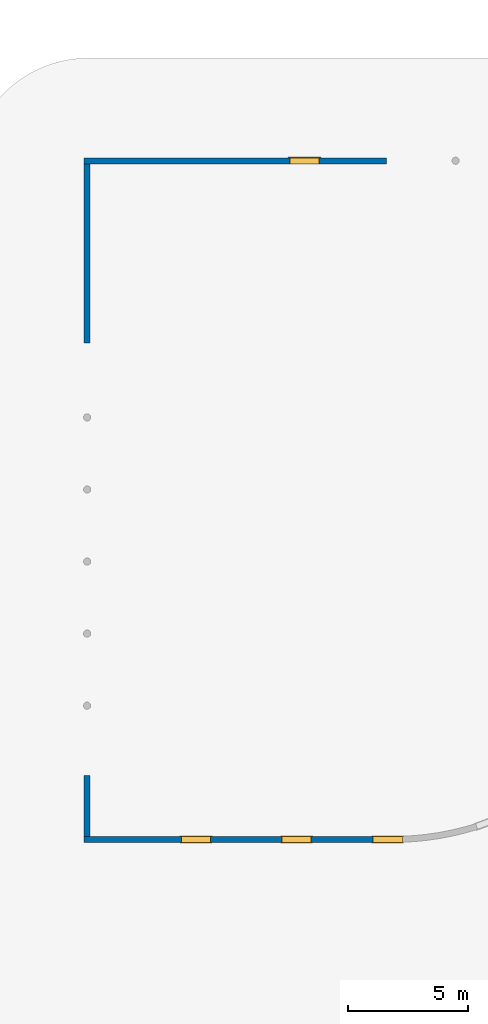
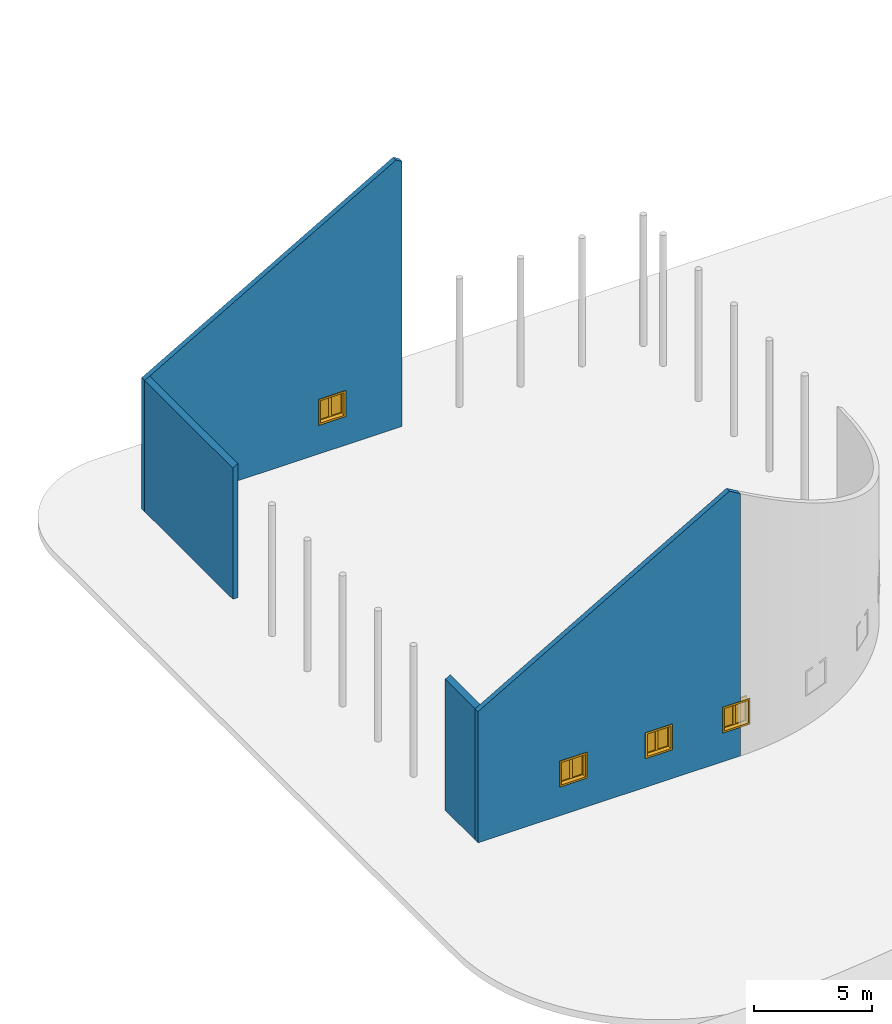
# One storey, part 7 of 39: 4 walls, 4 windows, 4 openings.
"""IFC2X3 building model written with IfcOpenShell, lengths in millimetres."""

from ifc_helpers import new_model, entity, si_unit, converted_unit, derived_unit, direction, frame, frame_2d, origin, origin_2d_with_axis, place, context, subcontext, project, spatial, polyline, rectangle, outline, extrude, clip, bounded_halfspace, source, transform, mapped, material, material_list, layer, layer_set, layer_usage, type_object, type_shapes, element, fill, save


model = new_model("IFC2X3")

# Units and contexts
model_context = context("Model", 3, precision=1e-06, world=origin(), true_north=direction((2.0, 6.12303176911189e-17, 1.0)))
context_of_model = context(None, 3, precision=1e-06, world=origin(), true_north=direction((2.0, 6.12303176911189e-17, 1.0)))
body_context = subcontext(model_context, "Body", "Model", "MODEL_VIEW")
ifc_project = project(units=[si_unit("LENGTHUNIT", "METRE", prefix="MILLI"), si_unit("AREAUNIT", "SQUARE_METRE", prefix="MILLI"), si_unit("VOLUMEUNIT", "CUBIC_METRE", prefix="MILLI"), converted_unit("PLANEANGLEUNIT", "DEGREE", entity("IfcRatioMeasure", 0.0174532925199433), si_unit("PLANEANGLEUNIT", "RADIAN"), dimensions=[0, 0, 0, 0, 0, 0, 0]), si_unit("MASSUNIT", "GRAM", prefix="KILO"), si_unit("TIMEUNIT", "SECOND"), si_unit("THERMODYNAMICTEMPERATUREUNIT", "KELVIN"), derived_unit("THERMALTRANSMITTANCEUNIT", [(si_unit("MASSUNIT", "GRAM", prefix="KILO"), 1), (si_unit("THERMODYNAMICTEMPERATUREUNIT", "KELVIN"), -1), (si_unit("TIMEUNIT", "SECOND"), -3)]), derived_unit("VOLUMETRICFLOWRATEUNIT", [(si_unit("LENGTHUNIT", "METRE"), 3), (si_unit("TIMEUNIT", "SECOND"), -1)])], contexts=[model_context, context_of_model])

# Site, building, storey
site_placement = place(None, origin())
site = spatial("IfcSite", under=ifc_project, at=site_placement, CompositionType="ELEMENT")
building_placement = place(site_placement, origin())
building = spatial("IfcBuilding", under=site, at=building_placement, CompositionType="ELEMENT")
storey_placement = place(building_placement, frame((0.0, 0.0, 4000.0)))
storey = spatial("IfcBuildingStorey", under=building, at=storey_placement, Name="Level 2", CompositionType="ELEMENT", Elevation=4000.0)

# Wall, openings, windows
ifc_material_1 = material(Name="Concrete - Cast In Situ")
ifc_layer = layer(ifc_material_1, 250.0)
ifc_layer_set = layer_set([ifc_layer], Name="Basic Wall:Structure wall")
ifc_layer_usage_1 = layer_usage(ifc_layer_set, "AXIS2", "NEGATIVE", 125.0)
wall_type = type_object("IfcWallType", Name="Basic Wall:Structure wall", PredefinedType="STANDARD", material=ifc_layer_set)
wall_1_placement = place(storey_placement, frame((-93797.4247632615, -15130.5876773198, 362.0)))
wall_1 = element("IfcWallStandardCase", 1, at=wall_1_placement, inside=storey, type_object=wall_type, material=ifc_layer_usage_1, Name="Basic Wall:Structure wall", ObjectType="Basic Wall:Structure wall", context=body_context, shape_type="Clipping", body=[
    clip(clip(extrude(rectangle(XDim=12850.0000000001, YDim=249.999999999999, at=frame_2d((6425.00000000006, 7.67386154620908e-13), x_axis=(-1.0, 0.0))), origin(), (0.0, 0.0, 1.0), 13883.7458783299), bounded_halfspace(frame((0.0, 125.0, 6782.33756729707), z_axis=(-0.500000000000008, 0.0, 0.866025403784434), x_axis=(0.0, -1.0, 0.0)), False, frame((0.0, 125.0, 6782.33756729707)), polyline([(0.0, 0.0), (0.0, -250.0), (12300.0, -250.0), (12300.0, 0.0), (250.0, 0.0), (0.0, 0.0)]))), bounded_halfspace(frame((12850.0, -125.0, 13566.2032302757), z_axis=(0.499999999999996, 0.0, 0.866025403784441), x_axis=(0.0, 1.0, 0.0)), False, frame((12850.0, -125.0, 13566.2032302757)), polyline([(0.0, 0.0), (0.0, 250.0), (-550.0, 250.0), (-550.0, 0.0), (0.0, 0.0)]))),
])
opening_1_placement = place(wall_1_placement, frame((12030.0, -125.0, 1553.0)))
opening_1 = element("IfcOpeningElement", 2, at=opening_1_placement, cuts=wall_1, Name="M_Casement Dbl with Trim:1220 x 1220mm:1220 x 1220mm:1", ObjectType="Opening", context=body_context, shape_type="SweptSolid", body=[
    extrude(rectangle(XDim=1220.0, YDim=1220.0, at=frame_2d((610.0, 610.0), x_axis=(-1.0, 0.0))), frame((0.0, 0.0, 0.0), z_axis=(0.0, 1.0, 0.0), x_axis=(0.0, 0.0, 1.0)), (0.0, 0.0, 1.0), 250.0),
])
opening_2_placement = place(wall_1_placement, frame((8240.05000000023, -125.0, 1553.0)))
opening_2 = element("IfcOpeningElement", 3, at=opening_2_placement, cuts=wall_1, Name="M_Casement Dbl with Trim:1220 x 1220mm:1220 x 1220mm:1", ObjectType="Opening", context=body_context, shape_type="SweptSolid", body=[
    extrude(rectangle(XDim=1220.0, YDim=1220.0, at=frame_2d((610.0, 610.0), x_axis=(-1.0, 0.0))), frame((0.0, 0.0, 0.0), z_axis=(0.0, 1.0, 0.0), x_axis=(0.0, 0.0, 1.0)), (0.0, 0.0, 1.0), 250.0),
])
opening_3_placement = place(wall_1_placement, frame((4050.10000000027, -125.0, 1553.0)))
opening_3 = element("IfcOpeningElement", 4, at=opening_3_placement, cuts=wall_1, Name="M_Casement Dbl with Trim:1220 x 1220mm:1220 x 1220mm:1", ObjectType="Opening", context=body_context, shape_type="SweptSolid", body=[
    extrude(rectangle(XDim=1220.0, YDim=1220.0, at=frame_2d((610.0, 610.0), x_axis=(-1.0, 0.0))), frame((0.0, 0.0, 0.0), z_axis=(0.0, 1.0, 0.0), x_axis=(0.0, 0.0, 1.0)), (0.0, 0.0, 1.0), 250.0),
])
ifc_material_2 = material(Name="Glass")
ifc_material_3 = material(Name="Sash")
ifc_material_4 = material(Name="Trim")
ifc_material_list_1 = material_list([ifc_material_2, ifc_material_3, ifc_material_4])
ifc_material_list_2 = material_list([ifc_material_2, ifc_material_3, ifc_material_4])
window_style = type_object("IfcWindowStyle", Name="1220 x 1220mm", ConstructionType="NOTDEFINED", OperationType="NOTDEFINED", ParameterTakesPrecedence=False, Sizeable=False, material=ifc_material_list_2)
shared_shape = source(origin(), body_context, "Body", "SweptSolid", [
    extrude(rectangle(XDim=12.7, YDim=482.999999999998, at=origin_2d_with_axis()), frame((915.0, 208.775, 63.5000000000002), z_axis=(0.0, 0.0, 1.0), x_axis=(0.0, -1.0, 0.0)), (0.0, 0.0, 1.0), 1093.0),
    extrude(outline(polyline([(-285.949999999999, -590.950000000002), (285.949999999999, -590.950000000002), (285.949999999999, 590.950000000003), (-285.949999999999, 590.950000000003), (-285.949999999999, -590.950000000002)]), holes=[polyline([(-241.499999999998, -546.500000000003), (-241.499999999998, 546.500000000002), (241.5, 546.500000000002), (241.5, -546.500000000003), (-241.499999999998, -546.500000000003)])]), frame((915.0, 186.55, 610.0), z_axis=(0.0, 1.0, 0.0), x_axis=(1.0, 0.0, 0.0)), (0.0, 0.0, 1.0), 44.45),
    extrude(rectangle(XDim=25.7, YDim=1359.89999999999, at=frame_2d((-1.68753899743024e-14, 0.0), x_axis=(1.0, 0.0))), frame((610.0, 262.85, 0.0), z_axis=(0.0, 0.0, 1.0), x_axis=(0.0, -1.0, 0.0)), (0.0, 0.0, 1.0), 19.0500000000014),
    extrude(outline(polyline([(-568.700000000007, 590.949999999995), (613.200000000007, 590.949999999995), (613.200000000007, 679.949999999994), (-657.700000000005, 679.949999999994), (-657.700000000005, -679.949999999993), (613.200000000006, -679.949999999993), (613.200000000006, -590.949999999995), (-568.700000000007, -590.949999999995), (-568.700000000007, 590.949999999995)])), frame((610.0, 250.0, 632.250000000007), z_axis=(0.0, 1.0, 0.0), x_axis=(0.0, 0.0, -1.0)), (0.0, 0.0, 1.0), 13.0),
    extrude(outline(polyline([(-667.25000000001, -667.249999999998), (667.25000000001, -667.249999999998), (667.25000000001, 667.249999999998), (-667.25000000001, 667.249999999998), (-667.25000000001, -667.249999999998)]), holes=[polyline([(-578.250000000011, -578.250000000001), (-578.250000000011, 578.249999999997), (578.24999999999, 578.249999999997), (578.24999999999, -578.250000000001), (-578.250000000011, -578.250000000001)])]), frame((610.0, -19.0, 610.0), z_axis=(0.0, 1.0, 0.0), x_axis=(0.0, 0.0, -1.0)), (0.0, 0.0, 1.0), 19.0),
    extrude(rectangle(XDim=12.7, YDim=482.999999999998, at=frame_2d((1.68753899743024e-14, 4.2632564145606e-14), x_axis=(1.0, 0.0))), frame((305.0, 208.775, 63.4999999999994), z_axis=(0.0, 0.0, 1.0), x_axis=(0.0, 1.0, 0.0)), (0.0, 0.0, 1.0), 1093.0),
    extrude(outline(polyline([(-285.949999999999, -590.950000000002), (285.949999999999, -590.950000000002), (285.949999999999, 590.950000000002), (-285.949999999999, 590.950000000002), (-285.949999999999, -590.950000000002)]), holes=[polyline([(-241.499999999999, -546.500000000003), (-241.499999999999, 546.500000000001), (241.499999999999, 546.500000000001), (241.499999999999, -546.500000000003), (-241.499999999999, -546.500000000003)])]), frame((305.0, 186.55, 610.0), z_axis=(0.0, 1.0, 0.0), x_axis=(1.0, 0.0, 0.0)), (0.0, 0.0, 1.0), 44.45),
    extrude(outline(polyline([(-610.0, -610.0), (610.0, -610.0), (610.0, 610.0), (-610.0, 610.0), (-610.0, -610.0)]), holes=[polyline([(-578.25, -578.250000000001), (-578.25, 578.25), (578.249999999997, 578.25), (578.249999999997, -578.250000000001), (-578.25, -578.250000000001)])]), frame((610.0, 0.0, 610.0), z_axis=(0.0, 1.0, 0.0), x_axis=(1.0, 0.0, 0.0)), (0.0, 0.0, 1.0), 186.55),
    extrude(outline(polyline([(-610.0, -610.0), (610.0, -610.0), (610.0, 610.0), (-610.0, 610.0), (-610.0, -610.0)]), holes=[polyline([(-590.950000000002, -590.949999999996), (-590.950000000002, 590.95), (590.950000000003, 590.95), (590.950000000003, -590.949999999996), (-590.950000000002, -590.949999999996)])]), frame((610.0, 186.55, 610.0), z_axis=(0.0, 1.0, 0.0), x_axis=(0.0, 0.0, -1.0)), (0.0, 0.0, 1.0), 63.45),
    extrude(rectangle(XDim=63.5, YDim=38.0999999999998, at=frame_2d((-8.88178419700125e-15, 0.0), x_axis=(1.0, 0.0))), frame((610.0, 218.3, 19.0499999999995), z_axis=(0.0, 0.0, 1.0), x_axis=(0.0, 1.0, 0.0)), (0.0, 0.0, 1.0), 1181.90000000001),
])
type_shapes(window_style, [shared_shape])
window_1_placement = place(opening_1_placement, origin())
window_1 = element("IfcWindow", 5, at=window_1_placement, inside=storey, type_object=window_style, material=ifc_material_list_1, Name="M_Casement Dbl with Trim:1220 x 1220mm", ObjectType="1220 x 1220mm", OverallHeight=1220.0, OverallWidth=1220.0, context=body_context, shape_type="MappedRepresentation", body=[
    mapped(shared_shape, transform((0.0, 0.0, 0.0), scale=1.0)),
])
fill(opening_1, window_1)
ifc_material_list_3 = material_list([ifc_material_2, ifc_material_3, ifc_material_4])
window_2_placement = place(opening_2_placement, origin())
window_2 = element("IfcWindow", 6, at=window_2_placement, inside=storey, type_object=window_style, material=ifc_material_list_3, Name="M_Casement Dbl with Trim:1220 x 1220mm", ObjectType="1220 x 1220mm", OverallHeight=1220.0, OverallWidth=1220.0, context=body_context, shape_type="MappedRepresentation", body=[
    mapped(shared_shape, transform((0.0, 0.0, 0.0), scale=1.0)),
])
fill(opening_2, window_2)
ifc_material_list_4 = material_list([ifc_material_2, ifc_material_3, ifc_material_4])
window_3_placement = place(opening_3_placement, origin())
window_3 = element("IfcWindow", 7, at=window_3_placement, inside=storey, type_object=window_style, material=ifc_material_list_4, Name="M_Casement Dbl with Trim:1220 x 1220mm", ObjectType="1220 x 1220mm", OverallHeight=1220.0, OverallWidth=1220.0, context=body_context, shape_type="MappedRepresentation", body=[
    mapped(shared_shape, transform((0.0, 0.0, 0.0), scale=1.0)),
])
fill(opening_3, window_3)

# Wall, opening, window
ifc_layer_usage_2 = layer_usage(ifc_layer_set, "AXIS2", "NEGATIVE", 125.0)
wall_2_placement = place(storey_placement, frame((-81211.4090773554, 13119.4123226802, 362.0), z_axis=(0.0, 0.0, 1.0), x_axis=(-1.0, 0.0, 0.0)))
wall_2 = element("IfcWallStandardCase", 8, at=wall_2_placement, inside=storey, type_object=wall_type, material=ifc_layer_usage_2, Name="Basic Wall:Structure wall", ObjectType="Basic Wall:Structure wall", context=body_context, shape_type="Clipping", body=[
    clip(clip(extrude(rectangle(XDim=12586.0156859063, YDim=249.999999999999, at=frame_2d((6293.00784295315, -2.34479102800833e-13), x_axis=(-1.0, 0.0))), origin(), (0.0, 0.0, 1.0), 13883.7458783299), bounded_halfspace(frame((286.015685905819, -125.0, 13883.7458783299), z_axis=(0.500000000000008, 0.0, 0.866025403784434), x_axis=(0.0, 1.0, 0.0)), False, frame((286.015685905819, -125.0, 13883.7458783299)), polyline([(0.0, 0.0), (12300.0, 0.0), (12300.0, 250.0), (12050.0, 250.0), (0.0, 250.0), (0.0, 0.0)]))), bounded_halfspace(frame((0.0, -125.0, 13718.6146450797), z_axis=(-0.499999999999996, 0.0, 0.866025403784441), x_axis=(0.0, -1.0, 0.0)), False, frame((0.0, -125.0, 13718.6146450797)), polyline([(0.0, 0.0), (286.015685905816, 0.0), (286.015685905817, 250.0), (0.0, 250.0), (0.0, 0.0)]))),
])
opening_4_placement = place(wall_2_placement, frame((4020.0, 125.0, 1553.0)))
opening_4 = element("IfcOpeningElement", 9, at=opening_4_placement, cuts=wall_2, Name="M_Casement Dbl with Trim:1220 x 1220mm:1220 x 1220mm:1", ObjectType="Opening", context=body_context, shape_type="SweptSolid", body=[
    extrude(rectangle(XDim=1220.0, YDim=1220.0, at=frame_2d((610.0, 610.0), x_axis=(-1.0, 0.0))), frame((0.0, 0.0, 0.0), z_axis=(0.0, -1.0, 0.0), x_axis=(0.0, 0.0, 1.0)), (0.0, 0.0, 1.0), 250.0),
])
ifc_material_list_5 = material_list([ifc_material_2, ifc_material_3, ifc_material_4])
window_4_placement = place(opening_4_placement, frame((0.0, 0.0, 0.0), z_axis=(0.0, 0.0, 1.0), x_axis=(-1.0, 0.0, 0.0)))
window_4 = element("IfcWindow", 10, at=window_4_placement, inside=storey, type_object=window_style, material=ifc_material_list_5, Name="M_Casement Dbl with Trim:1220 x 1220mm", ObjectType="1220 x 1220mm", OverallHeight=1220.0, OverallWidth=1220.0, context=body_context, shape_type="MappedRepresentation", body=[
    mapped(shared_shape, transform((0.0, 0.0, 0.0), scale=1.0)),
])
fill(opening_4, window_4)

# Walls
ifc_layer_usage_3 = layer_usage(ifc_layer_set, "AXIS2", "NEGATIVE", 125.0)
wall_3_placement = place(storey_placement, frame((-93672.4247632617, 12994.4123226802, 362.0), z_axis=(0.0, 0.0, 1.0), x_axis=(0.0, -1.0, 0.0)))
element("IfcWallStandardCase", 11, at=wall_3_placement, inside=storey, type_object=wall_type, material=ifc_layer_usage_3, Name="Basic Wall:Structure wall", ObjectType="Basic Wall:Structure wall", context=body_context, shape_type="Clipping", body=[
    clip(extrude(rectangle(XDim=7469.99999999967, YDim=250.000000000012, at=frame_2d((3734.99999999984, 3.96482846554136e-12), x_axis=(-1.0, 0.0))), origin(), (0.0, 0.0, 1.0), 8000.0), bounded_halfspace(frame((0.0, -125.0, 6782.33756729703), z_axis=(0.0, -0.500000000000008, 0.866025403784434), x_axis=(1.0, 0.0, 0.0)), False, frame((0.0, -125.0, 6782.33756729703)), polyline([(0.0, 0.0), (7470.0, 0.0), (7470.0, 250.0), (0.0, 250.0), (0.0, 0.0)]))),
])
ifc_layer_usage_4 = layer_usage(ifc_layer_set, "AXIS2", "NEGATIVE", 125.0)
wall_4_placement = place(storey_placement, frame((-93672.4247632615, -12475.5876773198, 362.0), z_axis=(0.0, 0.0, 1.0), x_axis=(0.0, -1.0, 0.0)))
element("IfcWallStandardCase", 12, at=wall_4_placement, inside=storey, type_object=wall_type, material=ifc_layer_usage_4, Name="Basic Wall:Structure wall", ObjectType="Basic Wall:Structure wall", context=body_context, shape_type="Clipping", body=[
    clip(extrude(rectangle(XDim=2530.00000000005, YDim=250.000000000012, at=frame_2d((1265.00000000003, 1.20081722343457e-12), x_axis=(-1.0, 0.0))), origin(), (0.0, 0.0, 1.0), 8000.0), bounded_halfspace(frame((0.0, -125.0, 6782.33756729707), z_axis=(0.0, -0.500000000000008, 0.866025403784434), x_axis=(1.0, 0.0, 0.0)), False, frame((0.0, -125.0, 6782.33756729707)), polyline([(0.0, 0.0), (2530.0, 0.0), (2530.0, 250.0), (0.0, 250.0), (0.0, 0.0)]))),
])

save(model, "model.ifc")
